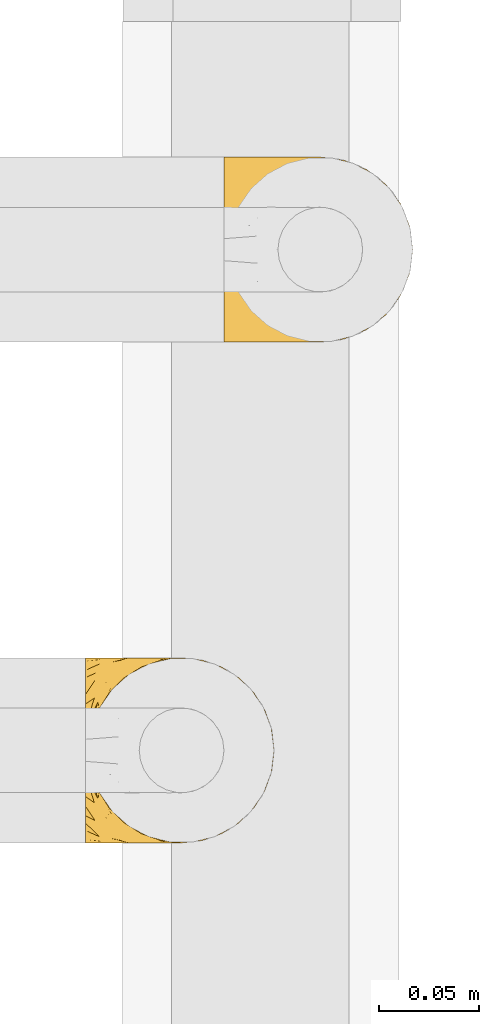
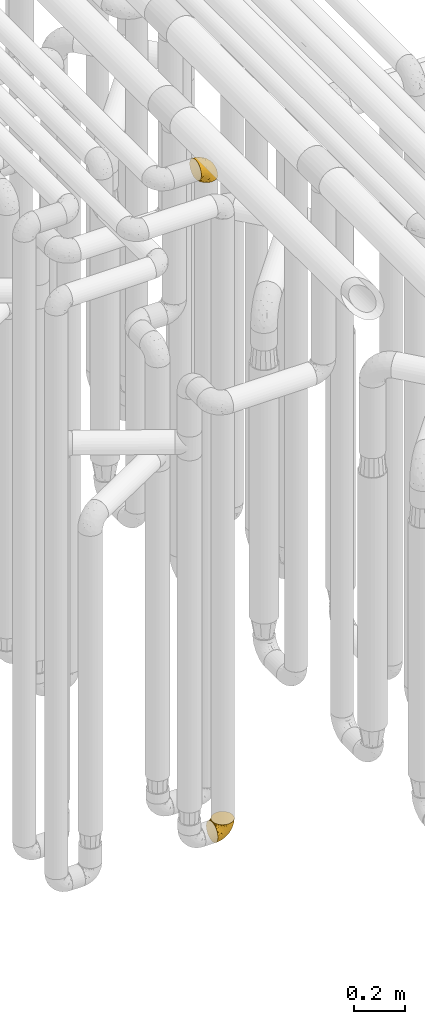
# One storey, part 200 of 827: 2 coverings.
"""IFC2X3 building model written with IfcOpenShell, lengths in millimetres."""

from ifc_helpers import new_model, entity, si_unit, converted_unit, derived_unit, direction, frame, origin, place, context, subcontext, project, spatial, faceted_brep, element, save


model = new_model("IFC2X3")

# Units and contexts
model_context = context("Model", 3, precision=0.01, world=origin(), true_north=direction((6.12303176911189e-17, 1.0)))
body_context = subcontext(model_context, "Body", "Model", "MODEL_VIEW")
ifc_project = project(units=[si_unit("LENGTHUNIT", "METRE", prefix="MILLI"), si_unit("AREAUNIT", "SQUARE_METRE"), si_unit("VOLUMEUNIT", "CUBIC_METRE"), converted_unit("PLANEANGLEUNIT", "DEGREE", entity("IfcRatioMeasure", 0.0174532925199433), si_unit("PLANEANGLEUNIT", "RADIAN"), dimensions=[0, 0, 0, 0, 0, 0, 0]), si_unit("MASSUNIT", "GRAM", prefix="KILO"), derived_unit("MASSDENSITYUNIT", [(si_unit("MASSUNIT", "GRAM", prefix="KILO"), 1), (si_unit("LENGTHUNIT", "METRE"), -3)]), derived_unit("MOMENTOFINERTIAUNIT", [(si_unit("LENGTHUNIT", "METRE"), 4)]), si_unit("TIMEUNIT", "SECOND"), si_unit("FREQUENCYUNIT", "HERTZ"), si_unit("THERMODYNAMICTEMPERATUREUNIT", "DEGREE_CELSIUS"), derived_unit("THERMALTRANSMITTANCEUNIT", [(si_unit("MASSUNIT", "GRAM", prefix="KILO"), 1), (si_unit("THERMODYNAMICTEMPERATUREUNIT", "KELVIN"), -1), (si_unit("TIMEUNIT", "SECOND"), -3)]), derived_unit("VOLUMETRICFLOWRATEUNIT", [(si_unit("LENGTHUNIT", "METRE"), 3), (si_unit("TIMEUNIT", "SECOND"), -1)]), derived_unit("MASSFLOWRATEUNIT", [(si_unit("MASSUNIT", "GRAM", prefix="KILO"), 1), (si_unit("TIMEUNIT", "SECOND"), -1)]), derived_unit("ROTATIONALFREQUENCYUNIT", [(si_unit("TIMEUNIT", "SECOND"), -1)]), si_unit("ELECTRICCURRENTUNIT", "AMPERE"), si_unit("ELECTRICVOLTAGEUNIT", "VOLT"), si_unit("POWERUNIT", "WATT"), si_unit("FORCEUNIT", "NEWTON", prefix="KILO"), si_unit("ILLUMINANCEUNIT", "LUX"), si_unit("LUMINOUSFLUXUNIT", "LUMEN"), si_unit("LUMINOUSINTENSITYUNIT", "CANDELA"), derived_unit("USERDEFINED", [(si_unit("MASSUNIT", "GRAM", prefix="KILO"), -1), (si_unit("LENGTHUNIT", "METRE"), -2), (si_unit("TIMEUNIT", "SECOND"), 3), (si_unit("LUMINOUSFLUXUNIT", "LUMEN"), 1)]), derived_unit("LINEARVELOCITYUNIT", [(si_unit("LENGTHUNIT", "METRE"), 1), (si_unit("TIMEUNIT", "SECOND"), -1)]), si_unit("PRESSUREUNIT", "PASCAL"), derived_unit("USERDEFINED", [(si_unit("LENGTHUNIT", "METRE"), -2), (si_unit("MASSUNIT", "GRAM", prefix="KILO"), 1), (si_unit("TIMEUNIT", "SECOND"), -2)]), derived_unit("LINEARFORCEUNIT", [(si_unit("MASSUNIT", "GRAM", prefix="KILO"), 1), (si_unit("LENGTHUNIT", "METRE"), 1), (si_unit("TIMEUNIT", "SECOND"), -2), (si_unit("LENGTHUNIT", "METRE"), -1)]), derived_unit("PLANARFORCEUNIT", [(si_unit("MASSUNIT", "GRAM", prefix="KILO"), 1), (si_unit("LENGTHUNIT", "METRE"), 1), (si_unit("TIMEUNIT", "SECOND"), -2), (si_unit("LENGTHUNIT", "METRE"), -2)])], contexts=[model_context])

# Site, building, storey
site_placement = place(None, origin())
site = spatial("IfcSite", under=ifc_project, at=site_placement, CompositionType="ELEMENT")
building_placement = place(site_placement, origin())
building = spatial("IfcBuilding", under=site, at=building_placement, CompositionType="ELEMENT")
storey_placement = place(building_placement, frame((0.0, 0.0, 28200.0)))
storey = spatial("IfcBuildingStorey", under=building, at=storey_placement, Name="08", CompositionType="ELEMENT", Elevation=28200.0)

# Coverings
covering_1_placement = place(storey_placement, frame((35898.45, 10558.41, 3350.4)))
element("IfcCovering", 1, at=covering_1_placement, inside=storey, Name=":ADSK_", ObjectType=":ADSK_", PredefinedType="INSULATION", context=body_context, shape_type="Brep", body=[
    faceted_brep([(1.6, 11.68, 78.41), (1.6, 19.0, 85.72), (1.6, 27.76, 91.22), (1.6, 37.52, 94.64), (1.6, 47.8, 95.8), (1.6, 58.08, 94.64), (1.6, 67.85, 91.22), (1.6, 76.61, 85.71), (1.6, 83.92, 78.39), (1.6, 89.42, 69.63), (1.6, 92.84, 59.87), (1.6, 94.0, 49.6), (1.6, 93.53, 45.45), (1.6, 93.18, 42.38), (1.6, 92.84, 39.31), (1.6, 91.13, 34.43), (1.6, 89.42, 29.54), (1.6, 86.66, 25.16), (1.6, 83.91, 20.78), (1.6, 80.25, 17.13), (1.6, 76.59, 13.47), (1.6, 67.83, 7.97), (1.6, 62.95, 6.26), (1.6, 58.07, 4.55), (1.6, 47.8, 3.4), (1.6, 37.51, 4.55), (1.6, 32.63, 6.26), (1.6, 27.74, 7.97), (1.6, 18.98, 13.48), (1.6, 15.33, 17.14), (1.6, 11.67, 20.8), (1.6, 8.92, 25.18), (1.6, 6.17, 29.56), (1.6, 4.46, 34.44), (1.6, 2.75, 39.32), (1.6, 2.41, 42.39), (1.6, 2.06, 45.45), (1.6, 1.6, 49.6), (1.6, 2.75, 59.88), (1.6, 6.17, 69.65), (3.4, 47.8, 1.6), (4.97, 59.75, 1.6), (9.58, 70.9, 1.6), (13.26, 75.68, 1.6), (16.93, 80.46, 1.6), (21.71, 84.13, 1.6), (26.5, 87.81, 1.6), (32.07, 90.11, 1.6), (37.64, 92.42, 1.6), (41.25, 92.9, 1.6), (43.34, 93.17, 1.6), (45.42, 93.45, 1.6), (49.6, 94.0, 1.6), (61.55, 92.42, 1.6), (72.7, 87.81, 1.6), (82.26, 80.46, 1.6), (89.61, 70.9, 1.6), (94.22, 59.75, 1.6), (95.8, 47.8, 1.6), (94.22, 35.84, 1.6), (89.61, 24.7, 1.6), (82.26, 15.13, 1.6), (72.7, 7.78, 1.6), (61.55, 3.17, 1.6), (49.6, 1.6, 1.6), (45.42, 2.14, 1.6), (41.25, 2.69, 1.6), (37.64, 3.17, 1.6), (32.07, 5.48, 1.6), (26.5, 7.78, 1.6), (21.71, 11.46, 1.6), (16.93, 15.13, 1.6), (13.26, 19.91, 1.6), (9.58, 24.7, 1.6), (4.97, 35.84, 1.6), (81.55, 23.61, 36.81), (90.4, 31.99, 23.28), (83.0, 35.87, 45.8), (91.18, 47.8, 30.7), (93.13, 40.43, 21.2), (94.0, 47.8, 12.96), (66.19, 31.83, 66.19), (70.92, 23.37, 54.51), (85.95, 21.41, 17.98), (49.74, 3.07, 36.69), (35.54, 1.6, 35.54), (38.14, 1.6, 31.64), (40.74, 1.6, 27.75), (43.34, 1.6, 23.86), (45.94, 1.6, 19.96), (77.59, 13.45, 22.8), (71.17, 15.25, 42.67), (65.81, 8.07, 33.21), (59.03, 16.0, 59.45), (45.85, 17.34, 71.5), (45.79, 10.58, 62.66), (41.42, 5.34, 54.5), (34.51, 2.39, 47.57), (56.04, 8.36, 48.81), (15.15, 10.04, 74.98), (56.51, 2.59, 18.7), (68.39, 6.28, 15.75), (23.33, 34.28, 91.17), (42.86, 38.73, 85.28), (39.42, 27.25, 82.58), (53.58, 29.88, 75.78), (59.17, 38.6, 74.98), (59.06, 23.44, 67.27), (22.63, 25.25, 87.38), (20.55, 17.23, 82.04), (12.96, 47.8, 94.0), (56.96, 47.8, 77.8), (67.38, 47.8, 67.38), (18.72, 2.53, 56.2), (5.33, 1.6, 48.85), (9.07, 1.6, 48.11), (11.79, 1.6, 47.57), (14.51, 1.6, 47.03), (17.24, 1.6, 46.48), (19.96, 1.6, 45.94), (21.03, 5.71, 65.78), (46.48, 1.6, 17.24), (47.03, 1.6, 14.51), (47.57, 1.6, 11.79), (48.11, 1.6, 9.07), (48.48, 1.6, 7.2), (48.85, 1.6, 5.33), (30.7, 47.8, 91.18), (23.86, 1.6, 43.34), (27.75, 1.6, 40.74), (31.64, 1.6, 38.14), (31.26, 11.89, 72.73), (77.8, 47.8, 56.96), (72.75, 39.69, 62.23), (43.83, 47.8, 84.49), (84.49, 47.8, 43.83), (14.58, 13.84, 12.05), (16.17, 9.16, 18.95), (10.82, 15.79, 13.02), (4.64, 25.75, 8.34), (7.71, 16.09, 14.63), (25.13, 7.51, 11.09), (32.66, 3.99, 13.66), (34.94, 2.66, 20.08), (36.76, 3.16, 9.61), (40.48, 2.35, 9.48), (39.25, 2.23, 16.1), (3.69, 38.35, 3.42), (13.99, 6.18, 26.63), (21.85, 2.7, 33.72), (17.93, 2.93, 34.77), (15.11, 16.01, 6.75), (21.14, 9.08, 13.31), (7.21, 11.68, 19.94), (12.7, 9.3, 21.11), (10.45, 21.65, 6.04), (32.27, 4.65, 8.67), (25.68, 3.65, 26.11), (22.18, 3.61, 29.3), (18.79, 12.8, 6.32), (10.12, 2.43, 39.92), (9.47, 6.83, 27.05), (11.29, 3.7, 34.4), (2.87, 47.8, 2.87), (31.16, 3.37, 20.92), (6.31, 7.03, 27.43), (25.62, 7.87, 7.54), (21.18, 7.26, 18.45), (28.81, 3.41, 23.88), (7.45, 23.81, 7.77), (21.17, 88.32, 18.43), (16.17, 86.42, 18.93), (25.69, 91.93, 26.08), (48.11, 94.0, 9.07), (48.85, 94.0, 5.33), (47.03, 94.0, 14.51), (47.57, 94.0, 11.79), (3.69, 57.24, 3.42), (7.44, 71.76, 7.76), (14.51, 94.0, 47.03), (11.79, 94.0, 47.57), (5.33, 94.0, 48.85), (9.07, 94.0, 48.11), (7.71, 79.49, 14.62), (9.47, 88.75, 27.03), (34.94, 92.93, 20.08), (31.16, 92.22, 20.92), (40.74, 94.0, 27.75), (38.14, 94.0, 31.64), (18.79, 82.79, 6.33), (36.76, 92.43, 9.61), (40.48, 93.24, 9.48), (4.63, 69.82, 8.33), (21.14, 86.5, 13.3), (15.11, 79.57, 6.74), (14.58, 81.74, 12.04), (43.34, 94.0, 23.86), (45.94, 94.0, 19.96), (39.25, 93.36, 16.1), (7.21, 83.9, 19.93), (12.69, 86.28, 21.1), (10.14, 93.16, 39.92), (21.81, 92.88, 33.68), (22.19, 91.98, 29.28), (14.0, 89.41, 26.62), (6.66, 88.82, 27.87), (17.92, 92.66, 34.75), (10.45, 73.93, 6.04), (31.64, 94.0, 38.14), (10.64, 79.5, 12.79), (11.31, 91.89, 34.41), (19.96, 94.0, 45.94), (23.86, 94.0, 43.34), (27.75, 94.0, 40.74), (32.66, 91.6, 13.66), (46.48, 94.0, 17.24), (32.27, 90.94, 8.67), (25.13, 88.08, 11.09), (35.54, 94.0, 35.54), (28.77, 92.16, 23.83), (23.36, 86.13, 6.03), (17.24, 94.0, 46.48), (47.58, 93.2, 34.52), (93.13, 55.16, 21.2), (77.44, 82.02, 23.82), (66.78, 84.29, 41.32), (71.68, 76.94, 47.62), (74.96, 68.33, 52.66), (81.55, 71.98, 36.81), (36.7, 92.52, 49.75), (56.9, 92.9, 19.07), (83.0, 59.72, 45.8), (90.4, 63.6, 23.28), (67.83, 88.89, 21.35), (85.95, 74.18, 17.98), (39.41, 68.35, 82.57), (23.33, 61.33, 91.17), (42.87, 56.86, 85.27), (53.92, 68.62, 73.89), (66.19, 63.76, 66.19), (64.12, 72.19, 62.43), (33.13, 88.69, 63.53), (23.1, 92.19, 58.45), (16.98, 89.75, 67.16), (55.72, 59.86, 76.72), (72.75, 55.9, 62.22), (23.77, 77.99, 81.54), (18.41, 85.21, 74.8), (43.7, 74.99, 75.83), (54.53, 90.23, 41.45), (17.73, 70.75, 88.2), (38.98, 81.72, 71.6), (50.28, 86.53, 56.23), (59.02, 79.6, 59.44)], [[[0, 1, 2, 3, 4, 5, 6, 7, 8, 9, 10, 11, 12, 13, 14, 15, 16, 17, 18, 19, 20, 21, 22, 23, 24, 25, 26, 27, 28, 29, 30, 31, 32, 33, 34, 35, 36, 37, 38, 39]], [[40, 41, 42, 43, 44, 45, 46, 47, 48, 49, 50, 51, 52, 53, 54, 55, 56, 57, 58, 59, 60, 61, 62, 63, 64, 65, 66, 67, 68, 69, 70, 71, 72, 73, 74]], [[75, 76, 77]], [[78, 79, 80]], [[77, 81, 82]], [[76, 75, 83]], [[84, 85, 86, 87, 88, 89]], [[90, 91, 92]], [[76, 60, 59]], [[93, 94, 95]], [[90, 62, 61]], [[83, 61, 60]], [[96, 97, 84]], [[98, 93, 95]], [[0, 39, 99]], [[100, 84, 89]], [[62, 101, 63]], [[2, 102, 3]], [[92, 84, 100]], [[103, 102, 104]], [[103, 105, 106]], [[93, 107, 94]], [[1, 108, 2]], [[92, 101, 90]], [[108, 1, 109]], [[102, 110, 3]], [[93, 82, 107]], [[102, 108, 104]], [[111, 106, 112]], [[109, 0, 99]], [[113, 37, 114, 115, 116, 117, 118, 119]], [[120, 38, 113]], [[100, 89, 121, 122, 123, 124, 125, 126, 64]], [[127, 102, 103]], [[97, 119, 128, 129, 130, 85]], [[99, 120, 131]], [[132, 133, 77]], [[59, 80, 79]], [[1, 0, 109]], [[98, 84, 92]], [[94, 109, 131]], [[120, 39, 38]], [[93, 91, 82]], [[104, 94, 105]], [[97, 113, 119]], [[95, 120, 96]], [[83, 90, 61]], [[91, 93, 98]], [[64, 63, 100]], [[100, 63, 101]], [[77, 76, 79]], [[133, 106, 81]], [[84, 97, 85]], [[113, 96, 120]], [[113, 97, 96]], [[37, 113, 38]], [[110, 102, 127]], [[110, 4, 3]], [[103, 111, 134, 127]], [[90, 75, 91]], [[82, 81, 107]], [[91, 75, 82]], [[77, 82, 75]], [[76, 83, 60]], [[90, 83, 75]], [[105, 107, 81]], [[94, 131, 95]], [[105, 94, 107]], [[109, 94, 104]], [[120, 95, 131]], [[98, 95, 96]], [[84, 98, 96]], [[98, 92, 91]], [[106, 105, 81]], [[103, 104, 105]], [[112, 106, 133]], [[103, 106, 111]], [[112, 133, 132]], [[81, 77, 133]], [[77, 78, 135, 132]], [[120, 99, 39]], [[109, 99, 131]], [[59, 58, 80]], [[59, 79, 76]], [[90, 101, 62]], [[100, 101, 92]], [[2, 108, 102]], [[109, 104, 108]], [[78, 77, 79]], [[136, 137, 138]], [[27, 139, 140]], [[141, 142, 143]], [[144, 145, 121]], [[146, 89, 88]], [[147, 139, 25]], [[148, 149, 150]], [[136, 151, 152]], [[147, 40, 74]], [[24, 147, 25]], [[153, 140, 154]], [[33, 116, 34]], [[73, 151, 155]], [[114, 37, 36, 35, 34, 116, 115]], [[146, 156, 144]], [[157, 85, 130]], [[158, 149, 148]], [[151, 159, 152]], [[117, 33, 160]], [[29, 153, 161]], [[155, 74, 73]], [[162, 128, 119]], [[66, 65, 64, 126, 125, 124, 123, 122, 67]], [[163, 147, 24]], [[27, 140, 28]], [[149, 129, 150]], [[139, 27, 26, 25]], [[68, 144, 69]], [[129, 128, 150]], [[164, 87, 86]], [[130, 129, 149]], [[122, 145, 67]], [[153, 154, 148]], [[162, 119, 160]], [[165, 30, 161]], [[150, 161, 148]], [[128, 162, 150]], [[30, 165, 31]], [[145, 144, 68]], [[89, 146, 144]], [[87, 164, 143]], [[166, 156, 142]], [[88, 87, 143]], [[162, 161, 150]], [[161, 30, 29]], [[161, 153, 148]], [[28, 140, 153]], [[29, 28, 153]], [[140, 137, 154]], [[158, 148, 154]], [[157, 130, 158]], [[154, 137, 158]], [[158, 137, 157]], [[167, 137, 136]], [[168, 85, 157]], [[152, 168, 167]], [[167, 168, 157]], [[164, 152, 141]], [[151, 73, 72]], [[159, 72, 71]], [[88, 142, 146]], [[144, 156, 69]], [[146, 142, 156]], [[70, 166, 71]], [[142, 141, 166]], [[70, 69, 156]], [[141, 159, 71]], [[167, 136, 152]], [[138, 137, 140]], [[155, 136, 169]], [[136, 155, 151]], [[74, 155, 169]], [[152, 159, 141]], [[151, 72, 159]], [[168, 152, 164]], [[137, 167, 157]], [[164, 86, 168]], [[85, 168, 86]], [[116, 33, 117]], [[130, 149, 158]], [[67, 145, 68]], [[121, 89, 144]], [[145, 122, 121]], [[40, 147, 163]], [[169, 147, 74]], [[160, 33, 32]], [[162, 160, 32]], [[160, 119, 118, 117]], [[139, 147, 169]], [[139, 169, 138]], [[162, 32, 31]], [[141, 143, 164]], [[88, 143, 142]], [[71, 166, 141]], [[156, 166, 70]], [[139, 138, 140]], [[169, 136, 138]], [[161, 162, 165]], [[162, 31, 165]], [[170, 171, 172]], [[173, 174, 52, 51, 50, 49, 48, 175, 176]], [[177, 178, 41]], [[179, 15, 180]], [[12, 11, 181, 182, 180, 14, 13]], [[183, 21, 20]], [[19, 18, 184]], [[185, 186, 187]], [[186, 188, 187]], [[43, 189, 44]], [[190, 191, 47]], [[23, 22, 21, 192]], [[193, 194, 195]], [[40, 163, 177]], [[196, 197, 198]], [[24, 23, 177]], [[199, 200, 183]], [[201, 15, 179]], [[178, 177, 192]], [[47, 46, 190]], [[202, 203, 204]], [[203, 172, 171]], [[205, 206, 184]], [[207, 41, 178]], [[16, 15, 201]], [[14, 180, 15]], [[204, 203, 200]], [[208, 203, 202]], [[163, 24, 177]], [[48, 47, 191]], [[198, 197, 190]], [[199, 184, 204]], [[171, 195, 209]], [[210, 211, 212]], [[206, 212, 213]], [[205, 17, 210]], [[184, 206, 204]], [[210, 212, 206]], [[185, 196, 214]], [[190, 215, 191]], [[216, 45, 214]], [[186, 217, 193]], [[190, 216, 198]], [[199, 20, 19]], [[196, 185, 187]], [[199, 183, 20]], [[184, 199, 19]], [[199, 204, 200]], [[206, 202, 204]], [[171, 183, 200]], [[203, 208, 172]], [[172, 208, 218]], [[171, 200, 203]], [[218, 188, 219]], [[195, 170, 193]], [[217, 186, 185]], [[193, 219, 186]], [[193, 170, 219]], [[207, 194, 42]], [[217, 220, 189]], [[216, 190, 46]], [[214, 196, 198]], [[44, 220, 45]], [[214, 198, 216]], [[216, 46, 45]], [[214, 45, 220]], [[42, 194, 43]], [[189, 193, 217]], [[207, 195, 194]], [[209, 195, 178]], [[41, 207, 42]], [[195, 207, 178]], [[43, 194, 189]], [[193, 189, 194]], [[171, 170, 195]], [[170, 172, 219]], [[218, 219, 172]], [[188, 186, 219]], [[206, 213, 202]], [[208, 202, 213]], [[201, 210, 16]], [[215, 190, 197]], [[215, 175, 191]], [[175, 48, 191]], [[201, 179, 221, 211]], [[210, 201, 211]], [[23, 192, 177]], [[40, 177, 41]], [[192, 183, 209]], [[21, 183, 192]], [[205, 18, 17]], [[17, 16, 210]], [[217, 185, 214]], [[189, 220, 44]], [[214, 220, 217]], [[192, 209, 178]], [[171, 209, 183]], [[206, 205, 210]], [[18, 205, 184]], [[222, 197, 196, 187, 188, 218]], [[57, 223, 80]], [[224, 225, 226]], [[226, 227, 228]], [[229, 218, 208, 213, 212, 211]], [[230, 52, 174, 173, 176, 175, 215, 197]], [[231, 232, 228]], [[231, 78, 223]], [[223, 57, 232]], [[224, 233, 225]], [[233, 54, 53]], [[234, 232, 56]], [[56, 55, 234]], [[234, 224, 228]], [[235, 236, 237]], [[224, 55, 54]], [[238, 239, 240]], [[52, 230, 53]], [[241, 242, 243]], [[239, 244, 245]], [[11, 10, 242]], [[236, 6, 5]], [[7, 246, 8]], [[8, 247, 9]], [[238, 248, 235]], [[222, 229, 249]], [[242, 211, 221, 179, 180, 182, 181, 11]], [[233, 53, 230]], [[111, 112, 244]], [[250, 6, 236]], [[247, 251, 241]], [[6, 250, 7]], [[127, 236, 110]], [[249, 229, 252]], [[247, 8, 246]], [[235, 246, 250]], [[236, 5, 110]], [[235, 244, 238]], [[237, 236, 127]], [[243, 9, 247]], [[252, 229, 241]], [[56, 232, 57]], [[222, 230, 197]], [[225, 249, 252]], [[249, 233, 230]], [[54, 233, 224]], [[231, 228, 227]], [[245, 132, 231]], [[249, 225, 233]], [[226, 225, 253]], [[235, 250, 236]], [[246, 7, 250]], [[251, 247, 246]], [[243, 247, 241]], [[248, 246, 235]], [[252, 251, 253]], [[229, 222, 218]], [[230, 222, 249]], [[5, 4, 110]], [[237, 127, 134, 111]], [[238, 244, 239]], [[224, 234, 55]], [[232, 234, 228]], [[242, 241, 229]], [[10, 9, 243]], [[211, 242, 229]], [[10, 243, 242]], [[80, 223, 78]], [[80, 58, 57]], [[231, 223, 232]], [[227, 240, 239]], [[224, 226, 228]], [[240, 226, 253]], [[227, 239, 245]], [[226, 240, 227]], [[251, 248, 253]], [[240, 253, 248]], [[244, 235, 237]], [[237, 111, 244]], [[132, 245, 112]], [[112, 245, 244]], [[135, 78, 231, 132]], [[227, 245, 231]], [[248, 238, 240]], [[246, 248, 251]], [[251, 252, 241]], [[225, 252, 253]]]),
])
covering_2_placement = place(storey_placement, frame((35829.19, 10308.37, 352.2)))
element("IfcCovering", 2, at=covering_2_placement, inside=storey, Name=":ADSK_", ObjectType=":ADSK_", PredefinedType="INSULATION", context=body_context, shape_type="Brep", body=[
    faceted_brep([(78.41, 11.68, 95.8), (85.72, 19.0, 95.8), (91.22, 27.76, 95.8), (94.64, 37.52, 95.8), (95.8, 47.8, 95.8), (94.64, 58.08, 95.8), (91.22, 67.85, 95.8), (85.71, 76.61, 95.8), (78.39, 83.92, 95.8), (69.63, 89.42, 95.8), (59.87, 92.84, 95.8), (49.6, 94.0, 95.8), (45.45, 93.53, 95.8), (42.38, 93.18, 95.8), (39.31, 92.84, 95.8), (34.43, 91.13, 95.8), (29.54, 89.42, 95.8), (25.16, 86.66, 95.8), (20.78, 83.91, 95.8), (17.13, 80.25, 95.8), (13.47, 76.59, 95.8), (7.97, 67.83, 95.8), (6.26, 62.95, 95.8), (4.55, 58.07, 95.8), (3.4, 47.8, 95.8), (4.55, 37.51, 95.8), (6.26, 32.63, 95.8), (7.97, 27.74, 95.8), (13.48, 18.98, 95.8), (17.14, 15.33, 95.8), (20.8, 11.67, 95.8), (25.18, 8.92, 95.8), (29.56, 6.17, 95.8), (34.44, 4.46, 95.8), (39.32, 2.75, 95.8), (42.39, 2.41, 95.8), (45.45, 2.06, 95.8), (49.6, 1.6, 95.8), (59.88, 2.75, 95.8), (69.65, 6.17, 95.8), (1.6, 47.8, 94.0), (1.6, 59.75, 92.42), (1.6, 70.9, 87.81), (1.6, 75.68, 84.13), (1.6, 80.46, 80.46), (1.6, 84.13, 75.68), (1.6, 87.81, 70.9), (1.6, 90.11, 65.32), (1.6, 92.42, 59.75), (1.6, 92.9, 56.14), (1.6, 93.17, 54.06), (1.6, 93.45, 51.97), (1.6, 94.0, 47.8), (1.6, 92.42, 35.84), (1.6, 87.81, 24.7), (1.6, 80.46, 15.13), (1.6, 70.9, 7.78), (1.6, 59.75, 3.17), (1.6, 47.8, 1.6), (1.6, 35.84, 3.17), (1.6, 24.7, 7.78), (1.6, 15.13, 15.13), (1.6, 7.78, 24.7), (1.6, 3.17, 35.84), (1.6, 1.6, 47.8), (1.6, 2.14, 51.97), (1.6, 2.69, 56.14), (1.6, 3.17, 59.75), (1.6, 5.48, 65.32), (1.6, 7.78, 70.9), (1.6, 11.46, 75.68), (1.6, 15.13, 80.46), (1.6, 19.91, 84.13), (1.6, 24.7, 87.81), (1.6, 35.84, 92.42), (36.81, 23.61, 15.84), (23.28, 31.99, 6.99), (45.8, 35.87, 14.39), (30.7, 47.8, 6.21), (21.2, 40.43, 4.26), (12.96, 47.8, 3.39), (66.19, 31.83, 31.2), (54.51, 23.37, 26.47), (17.98, 21.41, 11.44), (36.69, 3.07, 47.66), (35.54, 1.6, 61.85), (31.64, 1.6, 59.25), (27.75, 1.6, 56.65), (23.86, 1.6, 54.05), (19.96, 1.6, 51.45), (22.8, 13.45, 19.8), (42.67, 15.25, 26.22), (33.21, 8.07, 31.58), (59.45, 16.0, 38.36), (71.5, 17.34, 51.54), (62.66, 10.58, 51.6), (54.5, 5.34, 55.97), (47.57, 2.39, 62.88), (48.81, 8.36, 41.35), (74.98, 10.04, 82.24), (18.7, 2.59, 40.88), (15.75, 6.28, 29.0), (91.17, 34.28, 74.06), (85.28, 38.73, 54.53), (82.58, 27.25, 57.98), (75.78, 29.88, 43.81), (74.98, 38.6, 38.22), (67.27, 23.44, 38.33), (87.38, 25.25, 74.76), (82.04, 17.23, 76.85), (94.0, 47.8, 84.43), (77.8, 47.8, 40.43), (67.38, 47.8, 30.01), (56.2, 2.53, 78.67), (48.85, 1.6, 92.06), (48.11, 1.6, 88.32), (47.57, 1.6, 85.6), (47.03, 1.6, 82.88), (46.48, 1.6, 80.15), (45.94, 1.6, 77.43), (65.78, 5.71, 76.36), (17.24, 1.6, 50.91), (14.51, 1.6, 50.37), (11.79, 1.6, 49.82), (9.07, 1.6, 49.28), (7.2, 1.6, 48.91), (5.33, 1.6, 48.54), (91.18, 47.8, 66.69), (43.34, 1.6, 73.53), (40.74, 1.6, 69.64), (38.14, 1.6, 65.75), (72.73, 11.89, 66.13), (56.96, 47.8, 19.59), (62.23, 39.69, 24.64), (84.49, 47.8, 53.56), (43.83, 47.8, 12.9), (12.05, 13.84, 82.81), (18.95, 9.16, 81.22), (13.02, 15.79, 86.57), (8.34, 25.75, 92.75), (14.63, 16.09, 89.68), (11.09, 7.51, 72.26), (13.66, 3.99, 64.73), (20.08, 2.66, 62.45), (9.61, 3.16, 60.63), (9.48, 2.35, 56.91), (16.1, 2.23, 58.14), (3.42, 38.35, 93.7), (26.63, 6.18, 83.4), (33.72, 2.7, 75.54), (34.77, 2.93, 79.46), (6.75, 16.01, 82.28), (13.31, 9.08, 76.25), (21.11, 9.3, 84.69), (19.94, 11.68, 90.18), (8.67, 4.65, 65.12), (26.11, 3.65, 71.71), (29.3, 3.61, 75.21), (6.32, 12.8, 78.6), (39.92, 2.43, 87.27), (27.05, 6.83, 87.92), (6.04, 21.65, 86.94), (34.4, 3.7, 86.1), (2.87, 47.8, 94.52), (20.92, 3.37, 66.23), (27.43, 7.03, 91.08), (7.54, 7.87, 71.77), (18.45, 7.26, 76.21), (23.88, 3.41, 68.59), (7.77, 23.81, 89.94), (13.3, 86.5, 76.25), (11.09, 88.08, 72.26), (6.33, 82.79, 78.6), (9.07, 94.0, 49.28), (5.33, 94.0, 48.54), (14.51, 94.0, 50.37), (11.79, 94.0, 49.82), (3.42, 57.24, 93.7), (7.76, 71.76, 89.95), (47.03, 94.0, 82.88), (47.57, 94.0, 85.6), (48.85, 94.0, 92.06), (48.11, 94.0, 88.32), (14.62, 79.49, 89.68), (27.03, 88.75, 87.92), (20.08, 92.93, 62.45), (20.92, 92.22, 66.24), (27.75, 94.0, 56.65), (31.64, 94.0, 59.25), (9.61, 92.43, 60.63), (9.48, 93.24, 56.91), (8.33, 69.82, 92.76), (6.74, 79.57, 82.28), (12.04, 81.74, 82.81), (23.86, 94.0, 54.05), (19.96, 94.0, 51.45), (16.1, 93.36, 58.14), (19.93, 83.9, 90.18), (21.1, 86.28, 84.7), (39.92, 93.16, 87.25), (33.68, 92.88, 75.58), (29.28, 91.98, 75.2), (26.62, 89.41, 83.39), (26.08, 91.93, 71.7), (18.93, 86.42, 81.22), (27.87, 88.82, 90.73), (34.75, 92.66, 79.47), (6.04, 73.93, 86.94), (38.14, 94.0, 65.75), (12.79, 79.5, 86.75), (34.41, 91.89, 86.08), (45.94, 94.0, 77.43), (43.34, 94.0, 73.53), (40.74, 94.0, 69.64), (13.66, 91.6, 64.73), (17.24, 94.0, 50.91), (8.67, 90.94, 65.12), (35.54, 94.0, 61.85), (23.83, 92.16, 68.62), (18.43, 88.32, 76.22), (6.03, 86.13, 74.03), (46.48, 94.0, 80.15), (34.52, 93.2, 49.81), (21.2, 55.16, 4.26), (23.82, 82.02, 19.95), (41.32, 84.29, 30.61), (47.62, 76.94, 25.71), (52.66, 68.33, 22.43), (36.81, 71.98, 15.85), (49.75, 92.52, 60.69), (19.07, 92.9, 40.49), (45.8, 59.72, 14.39), (23.28, 63.6, 6.99), (21.35, 88.89, 29.56), (17.98, 74.18, 11.45), (82.57, 68.35, 57.98), (91.17, 61.33, 74.06), (85.27, 56.86, 54.52), (73.89, 68.62, 43.47), (66.19, 63.76, 31.2), (62.43, 72.19, 33.27), (63.53, 88.69, 64.26), (58.45, 92.19, 74.29), (67.16, 89.75, 80.41), (62.22, 55.9, 24.64), (81.54, 77.99, 73.62), (74.8, 85.21, 78.98), (75.83, 74.99, 53.69), (41.45, 90.23, 42.86), (76.72, 59.86, 41.67), (88.2, 70.75, 79.66), (71.6, 81.72, 58.41), (56.23, 86.53, 47.11), (59.44, 79.6, 38.37)], [[[0, 1, 2, 3, 4, 5, 6, 7, 8, 9, 10, 11, 12, 13, 14, 15, 16, 17, 18, 19, 20, 21, 22, 23, 24, 25, 26, 27, 28, 29, 30, 31, 32, 33, 34, 35, 36, 37, 38, 39]], [[40, 41, 42, 43, 44, 45, 46, 47, 48, 49, 50, 51, 52, 53, 54, 55, 56, 57, 58, 59, 60, 61, 62, 63, 64, 65, 66, 67, 68, 69, 70, 71, 72, 73, 74]], [[75, 76, 77]], [[78, 79, 80]], [[77, 81, 82]], [[76, 75, 83]], [[84, 85, 86, 87, 88, 89]], [[90, 91, 92]], [[76, 60, 59]], [[93, 94, 95]], [[90, 62, 61]], [[83, 61, 60]], [[96, 97, 84]], [[98, 93, 95]], [[0, 39, 99]], [[100, 84, 89]], [[62, 101, 63]], [[2, 102, 3]], [[92, 84, 100]], [[103, 102, 104]], [[103, 105, 106]], [[93, 107, 94]], [[1, 108, 2]], [[92, 101, 90]], [[108, 1, 109]], [[102, 110, 3]], [[93, 82, 107]], [[102, 108, 104]], [[111, 106, 112]], [[109, 0, 99]], [[113, 37, 114, 115, 116, 117, 118, 119]], [[120, 38, 113]], [[100, 89, 121, 122, 123, 124, 125, 126, 64]], [[127, 102, 103]], [[97, 119, 128, 129, 130, 85]], [[99, 120, 131]], [[132, 133, 77]], [[59, 80, 79]], [[1, 0, 109]], [[98, 84, 92]], [[94, 109, 131]], [[120, 39, 38]], [[93, 91, 82]], [[104, 94, 105]], [[97, 113, 119]], [[95, 120, 96]], [[83, 90, 61]], [[91, 93, 98]], [[64, 63, 100]], [[100, 63, 101]], [[77, 76, 79]], [[133, 106, 81]], [[84, 97, 85]], [[113, 96, 120]], [[113, 97, 96]], [[37, 113, 38]], [[110, 102, 127]], [[110, 4, 3]], [[103, 111, 134, 127]], [[90, 75, 91]], [[82, 81, 107]], [[91, 75, 82]], [[77, 82, 75]], [[76, 83, 60]], [[90, 83, 75]], [[105, 107, 81]], [[94, 131, 95]], [[105, 94, 107]], [[109, 94, 104]], [[120, 95, 131]], [[98, 95, 96]], [[84, 98, 96]], [[98, 92, 91]], [[106, 105, 81]], [[103, 104, 105]], [[112, 106, 133]], [[103, 106, 111]], [[112, 133, 132]], [[81, 77, 133]], [[77, 78, 135, 132]], [[120, 99, 39]], [[109, 99, 131]], [[59, 58, 80]], [[59, 79, 76]], [[90, 101, 62]], [[100, 101, 92]], [[2, 108, 102]], [[109, 104, 108]], [[78, 77, 79]], [[136, 137, 138]], [[27, 139, 140]], [[141, 142, 143]], [[144, 145, 121]], [[146, 89, 88]], [[147, 139, 25]], [[148, 149, 150]], [[136, 151, 152]], [[147, 40, 74]], [[24, 147, 25]], [[140, 153, 154]], [[33, 116, 34]], [[73, 72, 151]], [[114, 37, 36, 35, 34, 116, 115]], [[146, 155, 144]], [[156, 85, 130]], [[157, 149, 148]], [[151, 158, 152]], [[117, 33, 159]], [[29, 154, 160]], [[161, 74, 73]], [[162, 128, 119]], [[66, 65, 64, 126, 125, 124, 123, 122, 67]], [[163, 147, 24]], [[27, 140, 28]], [[149, 129, 150]], [[139, 27, 26, 25]], [[68, 144, 69]], [[129, 128, 150]], [[164, 87, 86]], [[130, 129, 149]], [[122, 145, 67]], [[154, 153, 148]], [[162, 119, 159]], [[165, 30, 160]], [[150, 160, 148]], [[128, 162, 150]], [[30, 165, 31]], [[145, 144, 68]], [[89, 146, 144]], [[87, 164, 143]], [[166, 155, 142]], [[88, 87, 143]], [[162, 160, 150]], [[160, 30, 29]], [[154, 29, 28]], [[140, 154, 28]], [[160, 154, 148]], [[140, 137, 153]], [[157, 148, 153]], [[156, 130, 157]], [[153, 137, 157]], [[157, 137, 156]], [[167, 137, 136]], [[168, 85, 156]], [[152, 168, 167]], [[167, 168, 156]], [[164, 152, 141]], [[71, 158, 72]], [[152, 167, 136]], [[88, 142, 146]], [[144, 155, 69]], [[146, 142, 155]], [[70, 166, 71]], [[142, 141, 166]], [[70, 69, 155]], [[141, 158, 71]], [[161, 73, 151]], [[138, 137, 140]], [[161, 136, 169]], [[136, 161, 151]], [[74, 161, 169]], [[152, 158, 141]], [[151, 72, 158]], [[168, 152, 164]], [[137, 167, 156]], [[164, 86, 168]], [[85, 168, 86]], [[116, 33, 117]], [[130, 149, 157]], [[67, 145, 68]], [[121, 89, 144]], [[145, 122, 121]], [[40, 147, 163]], [[169, 147, 74]], [[159, 33, 32]], [[162, 159, 32]], [[159, 119, 118, 117]], [[139, 147, 169]], [[139, 169, 138]], [[162, 32, 31]], [[141, 143, 164]], [[88, 143, 142]], [[71, 166, 141]], [[155, 166, 70]], [[139, 138, 140]], [[169, 136, 138]], [[160, 162, 165]], [[162, 31, 165]], [[170, 171, 172]], [[173, 174, 52, 51, 50, 49, 48, 175, 176]], [[177, 178, 41]], [[179, 15, 180]], [[12, 11, 181, 182, 180, 14, 13]], [[183, 21, 20]], [[19, 18, 184]], [[185, 186, 187]], [[186, 188, 187]], [[43, 172, 44]], [[189, 190, 47]], [[23, 22, 21, 191]], [[170, 192, 193]], [[40, 163, 177]], [[194, 195, 196]], [[24, 23, 177]], [[197, 198, 183]], [[199, 15, 179]], [[47, 46, 189]], [[200, 201, 202]], [[201, 203, 204]], [[205, 206, 184]], [[207, 41, 178]], [[16, 15, 199]], [[14, 180, 15]], [[202, 201, 198]], [[208, 201, 200]], [[163, 24, 177]], [[48, 47, 190]], [[196, 195, 189]], [[197, 184, 202]], [[204, 193, 209]], [[210, 211, 212]], [[206, 212, 213]], [[205, 17, 210]], [[184, 206, 202]], [[210, 212, 206]], [[185, 194, 214]], [[189, 215, 190]], [[216, 45, 214]], [[186, 171, 170]], [[189, 216, 196]], [[197, 20, 19]], [[194, 185, 187]], [[197, 183, 20]], [[184, 197, 19]], [[197, 202, 198]], [[206, 200, 202]], [[204, 183, 198]], [[201, 208, 203]], [[203, 208, 217]], [[204, 198, 201]], [[217, 188, 218]], [[193, 219, 170]], [[171, 186, 185]], [[170, 218, 186]], [[170, 219, 218]], [[42, 207, 192]], [[171, 220, 172]], [[216, 189, 46]], [[214, 194, 196]], [[44, 220, 45]], [[214, 196, 216]], [[216, 46, 45]], [[214, 45, 220]], [[192, 43, 42]], [[204, 203, 219]], [[207, 193, 192]], [[209, 193, 178]], [[41, 207, 42]], [[193, 207, 178]], [[43, 192, 172]], [[170, 172, 192]], [[204, 219, 193]], [[219, 203, 218]], [[217, 218, 203]], [[188, 186, 218]], [[206, 213, 200]], [[208, 200, 213]], [[199, 210, 16]], [[215, 189, 195]], [[215, 175, 190]], [[175, 48, 190]], [[199, 179, 221, 211]], [[210, 199, 211]], [[23, 191, 177]], [[40, 177, 41]], [[178, 177, 191]], [[21, 183, 191]], [[209, 191, 183]], [[205, 18, 17]], [[17, 16, 210]], [[171, 185, 214]], [[172, 220, 44]], [[214, 220, 171]], [[191, 209, 178]], [[204, 209, 183]], [[206, 205, 210]], [[18, 205, 184]], [[222, 195, 194, 187, 188, 217]], [[57, 223, 80]], [[224, 225, 226]], [[226, 227, 228]], [[229, 217, 208, 213, 212, 211]], [[230, 52, 174, 173, 176, 175, 215, 195]], [[231, 232, 228]], [[231, 78, 223]], [[223, 57, 232]], [[224, 233, 225]], [[233, 54, 53]], [[234, 232, 56]], [[56, 55, 234]], [[234, 224, 228]], [[235, 236, 237]], [[224, 55, 54]], [[238, 239, 240]], [[52, 230, 53]], [[241, 242, 243]], [[227, 244, 231]], [[11, 10, 242]], [[236, 6, 5]], [[7, 245, 8]], [[8, 246, 9]], [[238, 247, 235]], [[222, 229, 248]], [[242, 211, 221, 179, 180, 182, 181, 11]], [[233, 53, 230]], [[111, 112, 249]], [[250, 6, 236]], [[246, 251, 241]], [[6, 250, 7]], [[127, 236, 110]], [[248, 229, 252]], [[246, 8, 245]], [[235, 245, 250]], [[236, 5, 110]], [[235, 249, 238]], [[237, 236, 127]], [[243, 9, 246]], [[252, 229, 241]], [[56, 232, 57]], [[222, 230, 195]], [[225, 248, 252]], [[248, 233, 230]], [[54, 233, 224]], [[231, 228, 227]], [[244, 132, 231]], [[248, 225, 233]], [[226, 225, 253]], [[235, 250, 236]], [[245, 7, 250]], [[251, 246, 245]], [[243, 246, 241]], [[247, 245, 235]], [[252, 251, 253]], [[229, 222, 217]], [[230, 222, 248]], [[5, 4, 110]], [[237, 127, 134, 111]], [[238, 249, 239]], [[224, 234, 55]], [[232, 234, 228]], [[242, 241, 229]], [[10, 9, 243]], [[211, 242, 229]], [[10, 243, 242]], [[80, 223, 78]], [[80, 58, 57]], [[231, 223, 232]], [[227, 240, 239]], [[224, 226, 228]], [[240, 226, 253]], [[227, 239, 244]], [[226, 240, 227]], [[251, 247, 253]], [[240, 253, 247]], [[249, 235, 237]], [[237, 111, 249]], [[112, 132, 244]], [[112, 244, 249]], [[78, 231, 132, 135]], [[249, 244, 239]], [[247, 238, 240]], [[245, 247, 251]], [[251, 252, 241]], [[225, 252, 253]]]),
])

save(model, "model.ifc")
